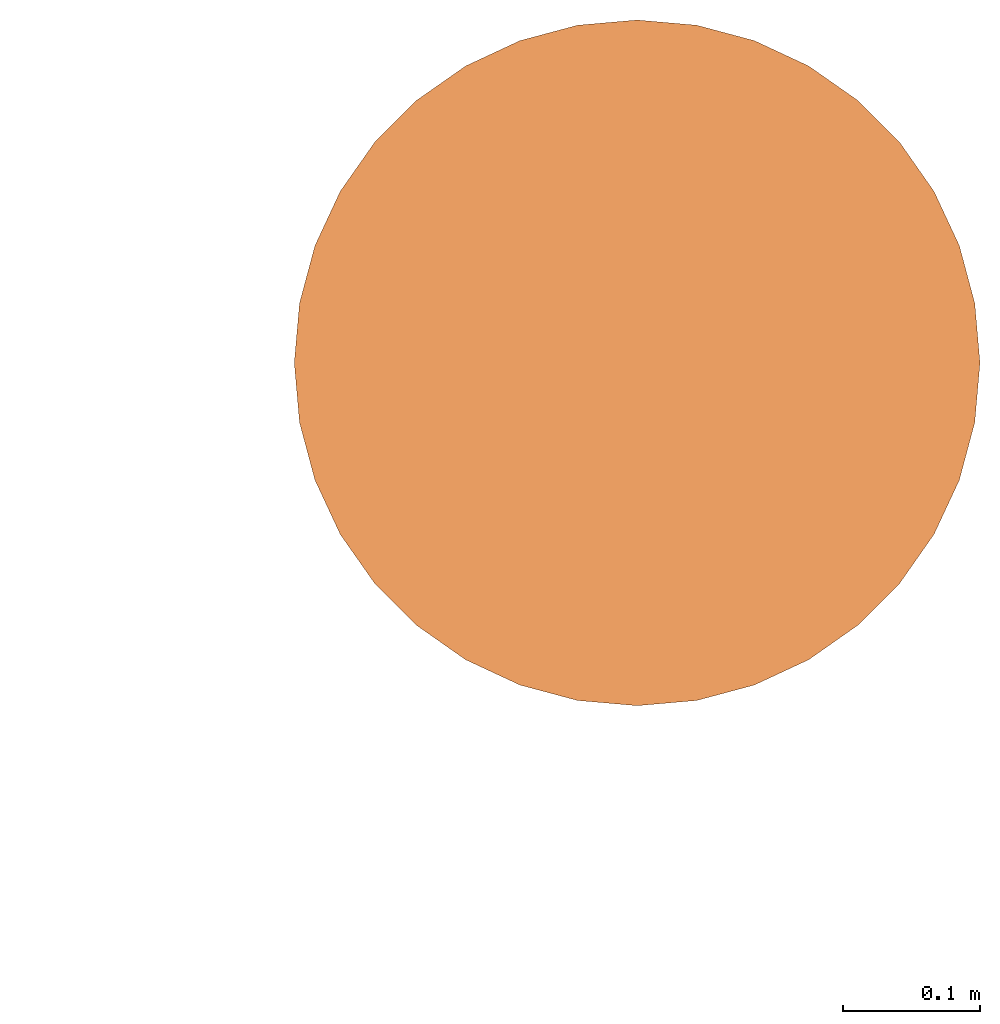
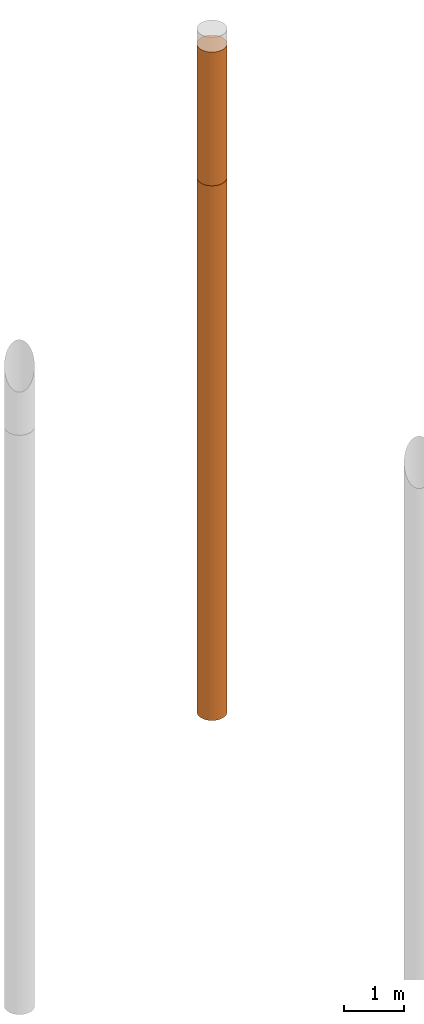
# One storey, part 5 of 8: 2 proxies.
"""IFC4 building model written with IfcOpenShell, lengths in metres."""

from ifc_helpers import new_model, entity, si_unit, converted_unit, frame, origin, place, context, subcontext, project, spatial, faceted_brep, material, element, save


model = new_model("IFC4")

# Units and contexts
model_context = context("Model", 3, precision=1e-05, world=origin())
body_context = subcontext(model_context, "Body", "Model", "MODEL_VIEW")
ifc_project = project(units=[si_unit("LENGTHUNIT", "METRE"), si_unit("AREAUNIT", "SQUARE_METRE"), si_unit("VOLUMEUNIT", "CUBIC_METRE"), converted_unit("PLANEANGLEUNIT", "DEGREE", entity("IfcPlaneAngleMeasure", 0.0174532925199433), si_unit("PLANEANGLEUNIT", "RADIAN"), dimensions=[0, 0, 0, 0, 0, 0, 0])], contexts=[model_context])

# Site, building, storey
site_placement = place(None, origin())
site = spatial("IfcSite", under=ifc_project, at=site_placement, CompositionType="ELEMENT")
building_placement = place(site_placement, origin())
building = spatial("IfcBuilding", under=site, at=building_placement, Name="Demo", CompositionType="ELEMENT")
storey_placement = place(building_placement, origin())
storey = spatial("IfcBuildingStorey", under=building, at=storey_placement, Name="Boden", CompositionType="ELEMENT", Elevation=0.0)

# Proxies
ifc_material_1 = material()
proxy_1_placement = place(storey_placement, frame((15.9, 13.51, -2.8)))
element("IfcBuildingElementProxy", 1, at=proxy_1_placement, inside=storey, material=ifc_material_1, Name="KB-03_Sand", PredefinedType="USERDEFINED", context=body_context, shape_type="Brep", body=[
    faceted_brep([(0.4962019382530489, 0.2934120444167329, 2.7), (0.5, 0.25, 2.7), (0.4962019382530489, 0.2065879555832671, 2.7), (0.4849231551964767, 0.1644949641685835, 2.7), (0.466506350946107, 0.125, 2.7), (0.441511110779742, 0.08930309757836585, 2.7), (0.4106969024216323, 0.05848888922025617, 2.7), (0.3749999999999982, 0.0334936490538912, 2.7), (0.3355050358314147, 0.01507684480352327, 2.7), (0.2934120444167311, 0.003798061746947497, 2.7), (0.2499999999999982, 0.0, 2.7), (0.2065879555832653, 0.003798061746947497, 2.7), (0.1644949641685816, 0.01507684480352327, 2.7), (0.1249999999999982, 0.03349364905388939, 2.7), (0.08930309757836404, 0.05848888922025617, 2.7), (0.05848888922025435, 0.08930309757836585, 2.7), (0.03349364905388939, 0.125, 2.7), (0.01507684480352145, 0.1644949641685835, 2.7), (0.003798061746945677, 0.2065879555832671, 2.7), (-1.818989403545857e-15, 0.25, 2.7), (0.003798061746945677, 0.2934120444167329, 2.7), (0.01507684480352145, 0.3355050358314166, 2.7), (0.03349364905388757, 0.375, 2.7), (0.05848888922025253, 0.4106969024216342, 2.7), (0.08930309757836222, 0.4415111107797439, 2.7), (0.1249999999999982, 0.4665063509461088, 2.7), (0.1644949641685798, 0.4849231551964767, 2.7), (0.2065879555832653, 0.4962019382530525, 2.7), (0.2499999999999982, 0.5, 2.7), (0.2934120444167293, 0.4962019382530525, 2.7), (0.3355050358314147, 0.4849231551964767, 2.7), (0.3749999999999982, 0.4665063509461107, 2.7), (0.4106969024216323, 0.4415111107797456, 2.7), (0.441511110779742, 0.410696902421636, 2.7), (0.466506350946107, 0.375, 2.7), (0.4849231551964767, 0.3355050358314184, 2.7), (0.5, 0.25, 0.0), (0.4962019382530489, 0.2934120444167329, 0.0), (0.4849231551964767, 0.3355050358314184, 0.0), (0.466506350946107, 0.375, 0.0), (0.441511110779742, 0.410696902421636, 0.0), (0.4106969024216323, 0.4415111107797456, 0.0), (0.3749999999999982, 0.4665063509461107, 0.0), (0.3355050358314147, 0.4849231551964767, 0.0), (0.2934120444167293, 0.4962019382530525, 0.0), (0.2499999999999982, 0.5, 0.0), (0.2065879555832653, 0.4962019382530507, 0.0), (0.1644949641685798, 0.4849231551964767, 0.0), (0.1249999999999982, 0.4665063509461088, 0.0), (0.08930309757836222, 0.4415111107797439, 0.0), (0.05848888922025253, 0.4106969024216342, 0.0), (0.03349364905388757, 0.375, 0.0), (0.01507684480352145, 0.3355050358314166, 0.0), (0.003798061746945677, 0.2934120444167311, 0.0), (-1.818989403545857e-15, 0.25, 0.0), (0.003798061746945677, 0.2065879555832671, 0.0), (0.01507684480352145, 0.1644949641685816, 0.0), (0.03349364905388939, 0.125, 0.0), (0.05848888922025435, 0.08930309757836404, 0.0), (0.08930309757836404, 0.05848888922025435, 0.0), (0.1249999999999982, 0.03349364905388939, 0.0), (0.1644949641685816, 0.01507684480352327, 0.0), (0.2065879555832653, 0.003798061746947497, 0.0), (0.2499999999999982, 0.0, 0.0), (0.2934120444167311, 0.003798061746947497, 0.0), (0.3355050358314147, 0.01507684480352327, 0.0), (0.3749999999999982, 0.03349364905388939, 0.0), (0.4106969024216323, 0.05848888922025435, 0.0), (0.441511110779742, 0.08930309757836404, 0.0), (0.466506350946107, 0.125, 0.0), (0.4849231551964767, 0.1644949641685816, 0.0), (0.4962019382530489, 0.2065879555832671, 0.0), (0.5, 0.25, 2.7), (0.4962019382530489, 0.2934120444167329, 2.7), (0.4962019382530489, 0.2934120444167329, 0.0), (0.5, 0.25, 0.0), (0.4962019382530489, 0.2065879555832671, 2.7), (0.5, 0.25, 2.7), (0.5, 0.25, 0.0), (0.4962019382530489, 0.2065879555832671, 0.0), (0.4849231551964767, 0.1644949641685835, 2.7), (0.4962019382530489, 0.2065879555832671, 2.7), (0.4962019382530489, 0.2065879555832671, 0.0), (0.4849231551964767, 0.1644949641685816, 0.0), (0.466506350946107, 0.125, 2.7), (0.4849231551964767, 0.1644949641685835, 2.7), (0.4849231551964767, 0.1644949641685816, 0.0), (0.466506350946107, 0.125, 0.0), (0.441511110779742, 0.08930309757836585, 2.7), (0.466506350946107, 0.125, 2.7), (0.466506350946107, 0.125, 0.0), (0.441511110779742, 0.08930309757836404, 0.0), (0.4106969024216323, 0.05848888922025617, 2.7), (0.441511110779742, 0.08930309757836585, 2.7), (0.441511110779742, 0.08930309757836404, 0.0), (0.4106969024216323, 0.05848888922025435, 0.0), (0.3749999999999982, 0.0334936490538912, 2.7), (0.4106969024216323, 0.05848888922025617, 2.7), (0.4106969024216323, 0.05848888922025435, 0.0), (0.3749999999999982, 0.03349364905388939, 0.0), (0.3355050358314147, 0.01507684480352327, 2.7), (0.3749999999999982, 0.0334936490538912, 2.7), (0.3749999999999982, 0.03349364905388939, 0.0), (0.3355050358314147, 0.01507684480352327, 0.0), (0.2934120444167311, 0.003798061746947497, 2.7), (0.3355050358314147, 0.01507684480352327, 2.7), (0.3355050358314147, 0.01507684480352327, 0.0), (0.2934120444167311, 0.003798061746947497, 0.0), (0.2499999999999982, 0.0, 2.7), (0.2934120444167311, 0.003798061746947497, 2.7), (0.2934120444167311, 0.003798061746947497, 0.0), (0.2499999999999982, 0.0, 0.0), (0.2065879555832653, 0.003798061746947497, 2.7), (0.2499999999999982, 0.0, 2.7), (0.2499999999999982, 0.0, 0.0), (0.2065879555832653, 0.003798061746947497, 0.0), (0.1644949641685816, 0.01507684480352327, 2.7), (0.2065879555832653, 0.003798061746947497, 2.7), (0.2065879555832653, 0.003798061746947497, 0.0), (0.1644949641685816, 0.01507684480352327, 0.0), (0.1249999999999982, 0.03349364905388939, 2.7), (0.1644949641685816, 0.01507684480352327, 2.7), (0.1644949641685816, 0.01507684480352327, 0.0), (0.1249999999999982, 0.03349364905388939, 0.0), (0.08930309757836404, 0.05848888922025617, 2.7), (0.1249999999999982, 0.03349364905388939, 2.7), (0.1249999999999982, 0.03349364905388939, 0.0), (0.08930309757836404, 0.05848888922025435, 0.0), (0.05848888922025435, 0.08930309757836585, 2.7), (0.08930309757836404, 0.05848888922025617, 2.7), (0.08930309757836404, 0.05848888922025435, 0.0), (0.05848888922025435, 0.08930309757836404, 0.0), (0.03349364905388939, 0.125, 2.7), (0.05848888922025435, 0.08930309757836585, 2.7), (0.05848888922025435, 0.08930309757836404, 0.0), (0.03349364905388939, 0.125, 0.0), (0.01507684480352145, 0.1644949641685835, 2.7), (0.03349364905388939, 0.125, 2.7), (0.03349364905388939, 0.125, 0.0), (0.01507684480352145, 0.1644949641685816, 0.0), (0.003798061746945677, 0.2065879555832671, 2.7), (0.01507684480352145, 0.1644949641685835, 2.7), (0.01507684480352145, 0.1644949641685816, 0.0), (0.003798061746945677, 0.2065879555832671, 0.0), (-1.818989403545857e-15, 0.25, 2.7), (0.003798061746945677, 0.2065879555832671, 2.7), (0.003798061746945677, 0.2065879555832671, 0.0), (-1.818989403545857e-15, 0.25, 0.0), (0.003798061746945677, 0.2934120444167329, 2.7), (-1.818989403545857e-15, 0.25, 2.7), (-1.818989403545857e-15, 0.25, 0.0), (0.003798061746945677, 0.2934120444167311, 0.0), (0.01507684480352145, 0.3355050358314166, 2.7), (0.003798061746945677, 0.2934120444167329, 2.7), (0.003798061746945677, 0.2934120444167311, 0.0), (0.01507684480352145, 0.3355050358314166, 0.0), (0.03349364905388757, 0.375, 2.7), (0.01507684480352145, 0.3355050358314166, 2.7), (0.01507684480352145, 0.3355050358314166, 0.0), (0.03349364905388757, 0.375, 0.0), (0.05848888922025253, 0.4106969024216342, 2.7), (0.03349364905388757, 0.375, 2.7), (0.03349364905388757, 0.375, 0.0), (0.05848888922025253, 0.4106969024216342, 0.0), (0.08930309757836222, 0.4415111107797439, 2.7), (0.05848888922025253, 0.4106969024216342, 2.7), (0.05848888922025253, 0.4106969024216342, 0.0), (0.08930309757836222, 0.4415111107797439, 0.0), (0.1249999999999982, 0.4665063509461088, 2.7), (0.08930309757836222, 0.4415111107797439, 2.7), (0.08930309757836222, 0.4415111107797439, 0.0), (0.1249999999999982, 0.4665063509461088, 0.0), (0.1644949641685798, 0.4849231551964767, 2.7), (0.1249999999999982, 0.4665063509461088, 2.7), (0.1249999999999982, 0.4665063509461088, 0.0), (0.1644949641685798, 0.4849231551964767, 0.0), (0.2065879555832653, 0.4962019382530525, 2.7), (0.1644949641685798, 0.4849231551964767, 2.7), (0.1644949641685798, 0.4849231551964767, 0.0), (0.2065879555832653, 0.4962019382530507, 0.0), (0.2499999999999982, 0.5, 2.7), (0.2065879555832653, 0.4962019382530525, 2.7), (0.2065879555832653, 0.4962019382530507, 0.0), (0.2499999999999982, 0.5, 0.0), (0.2934120444167293, 0.4962019382530525, 2.7), (0.2499999999999982, 0.5, 2.7), (0.2499999999999982, 0.5, 0.0), (0.2934120444167293, 0.4962019382530525, 0.0), (0.3355050358314147, 0.4849231551964767, 2.7), (0.2934120444167293, 0.4962019382530525, 2.7), (0.2934120444167293, 0.4962019382530525, 0.0), (0.3355050358314147, 0.4849231551964767, 0.0), (0.3749999999999982, 0.4665063509461107, 2.7), (0.3355050358314147, 0.4849231551964767, 2.7), (0.3355050358314147, 0.4849231551964767, 0.0), (0.3749999999999982, 0.4665063509461107, 0.0), (0.4106969024216323, 0.4415111107797456, 2.7), (0.3749999999999982, 0.4665063509461107, 2.7), (0.3749999999999982, 0.4665063509461107, 0.0), (0.4106969024216323, 0.4415111107797456, 0.0), (0.441511110779742, 0.410696902421636, 2.7), (0.4106969024216323, 0.4415111107797456, 2.7), (0.4106969024216323, 0.4415111107797456, 0.0), (0.441511110779742, 0.410696902421636, 0.0), (0.466506350946107, 0.375, 2.7), (0.441511110779742, 0.410696902421636, 2.7), (0.441511110779742, 0.410696902421636, 0.0), (0.466506350946107, 0.375, 0.0), (0.4849231551964767, 0.3355050358314184, 2.7), (0.466506350946107, 0.375, 2.7), (0.466506350946107, 0.375, 0.0), (0.4849231551964767, 0.3355050358314184, 0.0), (0.4962019382530489, 0.2934120444167329, 2.7), (0.4849231551964767, 0.3355050358314184, 2.7), (0.4849231551964767, 0.3355050358314184, 0.0), (0.4962019382530489, 0.2934120444167329, 0.0)], [[[0, 1, 2, 3, 4, 5, 6, 7, 8, 9, 10, 11, 12, 13, 14, 15, 16, 17, 18, 19, 20, 21, 22, 23, 24, 25, 26, 27, 28, 29, 30, 31, 32, 33, 34, 35]], [[36, 37, 38, 39, 40, 41, 42, 43, 44, 45, 46, 47, 48, 49, 50, 51, 52, 53, 54, 55, 56, 57, 58, 59, 60, 61, 62, 63, 64, 65, 66, 67, 68, 69, 70, 71]], [[72, 73, 74, 75]], [[76, 77, 78, 79]], [[80, 81, 82, 83]], [[84, 85, 86, 87]], [[88, 89, 90, 91]], [[92, 93, 94, 95]], [[96, 97, 98, 99]], [[100, 101, 102, 103]], [[104, 105, 106, 107]], [[108, 109, 110, 111]], [[112, 113, 114, 115]], [[116, 117, 118, 119]], [[120, 121, 122, 123]], [[124, 125, 126, 127]], [[128, 129, 130, 131]], [[132, 133, 134, 135]], [[136, 137, 138, 139]], [[140, 141, 142, 143]], [[144, 145, 146, 147]], [[148, 149, 150, 151]], [[152, 153, 154, 155]], [[156, 157, 158, 159]], [[160, 161, 162, 163]], [[164, 165, 166, 167]], [[168, 169, 170, 171]], [[172, 173, 174, 175]], [[176, 177, 178, 179]], [[180, 181, 182, 183]], [[184, 185, 186, 187]], [[188, 189, 190, 191]], [[192, 193, 194, 195]], [[196, 197, 198, 199]], [[200, 201, 202, 203]], [[204, 205, 206, 207]], [[208, 209, 210, 211]], [[212, 213, 214, 215]]], orient=[[False], [False], [False], [False], [False], [False], [False], [False], [False], [False], [False], [False], [False], [False], [False], [False], [False], [False], [False], [False], [False], [False], [False], [False], [False], [False], [False], [False], [False], [False], [False], [False], [False], [False], [False], [False], [False], [False]]),
])
ifc_material_2 = material()
proxy_2_placement = place(storey_placement, frame((15.9, 13.51, -13.6)))
element("IfcBuildingElementProxy", 2, at=proxy_2_placement, inside=storey, material=ifc_material_2, Name="KB-03_Kies", PredefinedType="USERDEFINED", context=body_context, shape_type="Brep", body=[
    faceted_brep([(0.4962019382530489, 0.2934120444167329, 10.8), (0.5, 0.25, 10.8), (0.4962019382530489, 0.2065879555832671, 10.8), (0.4849231551964767, 0.1644949641685835, 10.8), (0.466506350946107, 0.125, 10.8), (0.441511110779742, 0.08930309757836585, 10.8), (0.4106969024216323, 0.05848888922025617, 10.8), (0.3749999999999982, 0.0334936490538912, 10.8), (0.3355050358314147, 0.01507684480352327, 10.8), (0.2934120444167311, 0.003798061746947497, 10.8), (0.2499999999999982, 0.0, 10.8), (0.2065879555832653, 0.003798061746947497, 10.8), (0.1644949641685816, 0.01507684480352327, 10.8), (0.1249999999999982, 0.03349364905388939, 10.8), (0.08930309757836404, 0.05848888922025617, 10.8), (0.05848888922025435, 0.08930309757836585, 10.8), (0.03349364905388939, 0.125, 10.8), (0.01507684480352145, 0.1644949641685835, 10.8), (0.003798061746945677, 0.2065879555832671, 10.8), (-1.818989403545857e-15, 0.25, 10.8), (0.003798061746945677, 0.2934120444167329, 10.8), (0.01507684480352145, 0.3355050358314166, 10.8), (0.03349364905388757, 0.375, 10.8), (0.05848888922025253, 0.4106969024216342, 10.8), (0.08930309757836222, 0.4415111107797439, 10.8), (0.1249999999999982, 0.4665063509461088, 10.8), (0.1644949641685798, 0.4849231551964767, 10.8), (0.2065879555832653, 0.4962019382530525, 10.8), (0.2499999999999982, 0.5, 10.8), (0.2934120444167293, 0.4962019382530525, 10.8), (0.3355050358314147, 0.4849231551964767, 10.8), (0.3749999999999982, 0.4665063509461107, 10.8), (0.4106969024216323, 0.4415111107797456, 10.8), (0.441511110779742, 0.410696902421636, 10.8), (0.466506350946107, 0.375, 10.8), (0.4849231551964767, 0.3355050358314184, 10.8), (0.5, 0.2499999999999982, 0.0), (0.4962019382530489, 0.2934120444167329, 0.0), (0.4849231551964767, 0.3355050358314166, 0.0), (0.466506350946107, 0.375, 0.0), (0.441511110779742, 0.4106969024216342, 0.0), (0.4106969024216323, 0.4415111107797439, 0.0), (0.3749999999999982, 0.4665063509461088, 0.0), (0.3355050358314147, 0.4849231551964767, 0.0), (0.2934120444167293, 0.4962019382530507, 0.0), (0.2499999999999982, 0.4999999999999982, 0.0), (0.2065879555832653, 0.4962019382530507, 0.0), (0.1644949641685798, 0.4849231551964749, 0.0), (0.1249999999999982, 0.4665063509461088, 0.0), (0.08930309757836222, 0.441511110779742, 0.0), (0.05848888922025253, 0.4106969024216323, 0.0), (0.03349364905388757, 0.3749999999999982, 0.0), (0.01507684480352145, 0.3355050358314147, 0.0), (0.003798061746945677, 0.2934120444167311, 0.0), (-1.818989403545857e-15, 0.2499999999999982, 0.0), (0.003798061746945677, 0.2065879555832653, 0.0), (0.01507684480352145, 0.1644949641685816, 0.0), (0.03349364905388939, 0.1249999999999982, 0.0), (0.05848888922025435, 0.08930309757836404, 0.0), (0.08930309757836404, 0.05848888922025435, 0.0), (0.1249999999999982, 0.03349364905388939, 0.0), (0.1644949641685816, 0.01507684480352145, 0.0), (0.2065879555832653, 0.003798061746947497, 0.0), (0.2499999999999982, -1.818989403545857e-15, 0.0), (0.2934120444167311, 0.003798061746947497, 0.0), (0.3355050358314147, 0.01507684480352145, 0.0), (0.3749999999999982, 0.03349364905388939, 0.0), (0.4106969024216323, 0.05848888922025435, 0.0), (0.441511110779742, 0.08930309757836404, 0.0), (0.466506350946107, 0.1249999999999982, 0.0), (0.4849231551964767, 0.1644949641685816, 0.0), (0.4962019382530489, 0.2065879555832653, 0.0), (0.5, 0.25, 10.8), (0.4962019382530489, 0.2934120444167329, 10.8), (0.4962019382530489, 0.2934120444167329, 0.0), (0.5, 0.2499999999999982, 0.0), (0.4962019382530489, 0.2065879555832671, 10.8), (0.5, 0.25, 10.8), (0.5, 0.2499999999999982, 0.0), (0.4962019382530489, 0.2065879555832653, 0.0), (0.4849231551964767, 0.1644949641685835, 10.8), (0.4962019382530489, 0.2065879555832671, 10.8), (0.4962019382530489, 0.2065879555832653, 0.0), (0.4849231551964767, 0.1644949641685816, 0.0), (0.466506350946107, 0.125, 10.8), (0.4849231551964767, 0.1644949641685835, 10.8), (0.4849231551964767, 0.1644949641685816, 0.0), (0.466506350946107, 0.1249999999999982, 0.0), (0.441511110779742, 0.08930309757836585, 10.8), (0.466506350946107, 0.125, 10.8), (0.466506350946107, 0.1249999999999982, 0.0), (0.441511110779742, 0.08930309757836404, 0.0), (0.4106969024216323, 0.05848888922025617, 10.8), (0.441511110779742, 0.08930309757836585, 10.8), (0.441511110779742, 0.08930309757836404, 0.0), (0.4106969024216323, 0.05848888922025435, 0.0), (0.3749999999999982, 0.0334936490538912, 10.8), (0.4106969024216323, 0.05848888922025617, 10.8), (0.4106969024216323, 0.05848888922025435, 0.0), (0.3749999999999982, 0.03349364905388939, 0.0), (0.3355050358314147, 0.01507684480352327, 10.8), (0.3749999999999982, 0.0334936490538912, 10.8), (0.3749999999999982, 0.03349364905388939, 0.0), (0.3355050358314147, 0.01507684480352145, 0.0), (0.2934120444167311, 0.003798061746947497, 10.8), (0.3355050358314147, 0.01507684480352327, 10.8), (0.3355050358314147, 0.01507684480352145, 0.0), (0.2934120444167311, 0.003798061746947497, 0.0), (0.2499999999999982, 0.0, 10.8), (0.2934120444167311, 0.003798061746947497, 10.8), (0.2934120444167311, 0.003798061746947497, 0.0), (0.2499999999999982, -1.818989403545857e-15, 0.0), (0.2065879555832653, 0.003798061746947497, 10.8), (0.2499999999999982, 0.0, 10.8), (0.2499999999999982, -1.818989403545857e-15, 0.0), (0.2065879555832653, 0.003798061746947497, 0.0), (0.1644949641685816, 0.01507684480352327, 10.8), (0.2065879555832653, 0.003798061746947497, 10.8), (0.2065879555832653, 0.003798061746947497, 0.0), (0.1644949641685816, 0.01507684480352145, 0.0), (0.1249999999999982, 0.03349364905388939, 10.8), (0.1644949641685816, 0.01507684480352327, 10.8), (0.1644949641685816, 0.01507684480352145, 0.0), (0.1249999999999982, 0.03349364905388939, 0.0), (0.08930309757836404, 0.05848888922025617, 10.8), (0.1249999999999982, 0.03349364905388939, 10.8), (0.1249999999999982, 0.03349364905388939, 0.0), (0.08930309757836404, 0.05848888922025435, 0.0), (0.05848888922025435, 0.08930309757836585, 10.8), (0.08930309757836404, 0.05848888922025617, 10.8), (0.08930309757836404, 0.05848888922025435, 0.0), (0.05848888922025435, 0.08930309757836404, 0.0), (0.03349364905388939, 0.125, 10.8), (0.05848888922025435, 0.08930309757836585, 10.8), (0.05848888922025435, 0.08930309757836404, 0.0), (0.03349364905388939, 0.1249999999999982, 0.0), (0.01507684480352145, 0.1644949641685835, 10.8), (0.03349364905388939, 0.125, 10.8), (0.03349364905388939, 0.1249999999999982, 0.0), (0.01507684480352145, 0.1644949641685816, 0.0), (0.003798061746945677, 0.2065879555832671, 10.8), (0.01507684480352145, 0.1644949641685835, 10.8), (0.01507684480352145, 0.1644949641685816, 0.0), (0.003798061746945677, 0.2065879555832653, 0.0), (-1.818989403545857e-15, 0.25, 10.8), (0.003798061746945677, 0.2065879555832671, 10.8), (0.003798061746945677, 0.2065879555832653, 0.0), (-1.818989403545857e-15, 0.2499999999999982, 0.0), (0.003798061746945677, 0.2934120444167329, 10.8), (-1.818989403545857e-15, 0.25, 10.8), (-1.818989403545857e-15, 0.2499999999999982, 0.0), (0.003798061746945677, 0.2934120444167311, 0.0), (0.01507684480352145, 0.3355050358314166, 10.8), (0.003798061746945677, 0.2934120444167329, 10.8), (0.003798061746945677, 0.2934120444167311, 0.0), (0.01507684480352145, 0.3355050358314147, 0.0), (0.03349364905388757, 0.375, 10.8), (0.01507684480352145, 0.3355050358314166, 10.8), (0.01507684480352145, 0.3355050358314147, 0.0), (0.03349364905388757, 0.3749999999999982, 0.0), (0.05848888922025253, 0.4106969024216342, 10.8), (0.03349364905388757, 0.375, 10.8), (0.03349364905388757, 0.3749999999999982, 0.0), (0.05848888922025253, 0.4106969024216323, 0.0), (0.08930309757836222, 0.4415111107797439, 10.8), (0.05848888922025253, 0.4106969024216342, 10.8), (0.05848888922025253, 0.4106969024216323, 0.0), (0.08930309757836222, 0.441511110779742, 0.0), (0.1249999999999982, 0.4665063509461088, 10.8), (0.08930309757836222, 0.4415111107797439, 10.8), (0.08930309757836222, 0.441511110779742, 0.0), (0.1249999999999982, 0.4665063509461088, 0.0), (0.1644949641685798, 0.4849231551964767, 10.8), (0.1249999999999982, 0.4665063509461088, 10.8), (0.1249999999999982, 0.4665063509461088, 0.0), (0.1644949641685798, 0.4849231551964749, 0.0), (0.2065879555832653, 0.4962019382530525, 10.8), (0.1644949641685798, 0.4849231551964767, 10.8), (0.1644949641685798, 0.4849231551964749, 0.0), (0.2065879555832653, 0.4962019382530507, 0.0), (0.2499999999999982, 0.5, 10.8), (0.2065879555832653, 0.4962019382530525, 10.8), (0.2065879555832653, 0.4962019382530507, 0.0), (0.2499999999999982, 0.4999999999999982, 0.0), (0.2934120444167293, 0.4962019382530525, 10.8), (0.2499999999999982, 0.5, 10.8), (0.2499999999999982, 0.4999999999999982, 0.0), (0.2934120444167293, 0.4962019382530507, 0.0), (0.3355050358314147, 0.4849231551964767, 10.8), (0.2934120444167293, 0.4962019382530525, 10.8), (0.2934120444167293, 0.4962019382530507, 0.0), (0.3355050358314147, 0.4849231551964767, 0.0), (0.3749999999999982, 0.4665063509461107, 10.8), (0.3355050358314147, 0.4849231551964767, 10.8), (0.3355050358314147, 0.4849231551964767, 0.0), (0.3749999999999982, 0.4665063509461088, 0.0), (0.4106969024216323, 0.4415111107797456, 10.8), (0.3749999999999982, 0.4665063509461107, 10.8), (0.3749999999999982, 0.4665063509461088, 0.0), (0.4106969024216323, 0.4415111107797439, 0.0), (0.441511110779742, 0.410696902421636, 10.8), (0.4106969024216323, 0.4415111107797456, 10.8), (0.4106969024216323, 0.4415111107797439, 0.0), (0.441511110779742, 0.4106969024216342, 0.0), (0.466506350946107, 0.375, 10.8), (0.441511110779742, 0.410696902421636, 10.8), (0.441511110779742, 0.4106969024216342, 0.0), (0.466506350946107, 0.375, 0.0), (0.4849231551964767, 0.3355050358314184, 10.8), (0.466506350946107, 0.375, 10.8), (0.466506350946107, 0.375, 0.0), (0.4849231551964767, 0.3355050358314166, 0.0), (0.4962019382530489, 0.2934120444167329, 10.8), (0.4849231551964767, 0.3355050358314184, 10.8), (0.4849231551964767, 0.3355050358314166, 0.0), (0.4962019382530489, 0.2934120444167329, 0.0)], [[[0, 1, 2, 3, 4, 5, 6, 7, 8, 9, 10, 11, 12, 13, 14, 15, 16, 17, 18, 19, 20, 21, 22, 23, 24, 25, 26, 27, 28, 29, 30, 31, 32, 33, 34, 35]], [[36, 37, 38, 39, 40, 41, 42, 43, 44, 45, 46, 47, 48, 49, 50, 51, 52, 53, 54, 55, 56, 57, 58, 59, 60, 61, 62, 63, 64, 65, 66, 67, 68, 69, 70, 71]], [[72, 73, 74, 75]], [[76, 77, 78, 79]], [[80, 81, 82, 83]], [[84, 85, 86, 87]], [[88, 89, 90, 91]], [[92, 93, 94, 95]], [[96, 97, 98, 99]], [[100, 101, 102, 103]], [[104, 105, 106, 107]], [[108, 109, 110, 111]], [[112, 113, 114, 115]], [[116, 117, 118, 119]], [[120, 121, 122, 123]], [[124, 125, 126, 127]], [[128, 129, 130, 131]], [[132, 133, 134, 135]], [[136, 137, 138, 139]], [[140, 141, 142, 143]], [[144, 145, 146, 147]], [[148, 149, 150, 151]], [[152, 153, 154, 155]], [[156, 157, 158, 159]], [[160, 161, 162, 163]], [[164, 165, 166, 167]], [[168, 169, 170, 171]], [[172, 173, 174, 175]], [[176, 177, 178, 179]], [[180, 181, 182, 183]], [[184, 185, 186, 187]], [[188, 189, 190, 191]], [[192, 193, 194, 195]], [[196, 197, 198, 199]], [[200, 201, 202, 203]], [[204, 205, 206, 207]], [[208, 209, 210, 211]], [[212, 213, 214, 215]]], orient=[[False], [False], [False], [False], [False], [False], [False], [False], [False], [False], [False], [False], [False], [False], [False], [False], [False], [False], [False], [False], [False], [False], [False], [False], [False], [False], [False], [False], [False], [False], [False], [False], [False], [False], [False], [False], [False], [False]]),
])

save(model, "model.ifc")
